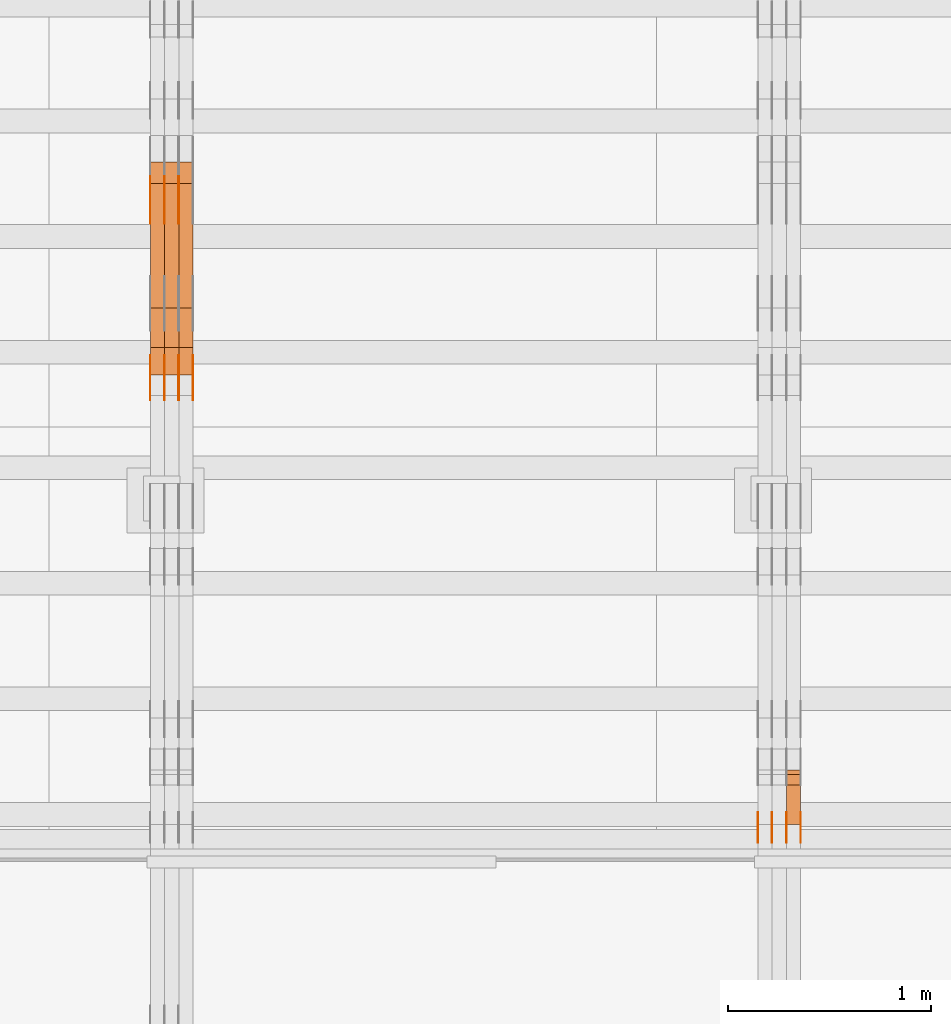
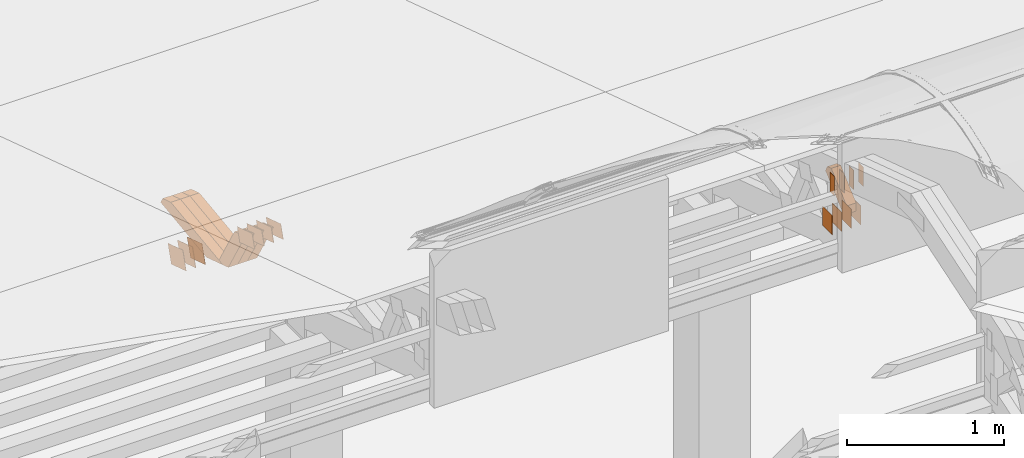
# One storey, part 288 of 385: 30 proxies.
"""IFC2X3 building model written with IfcOpenShell, lengths in millimetres."""

import ifcopenshell
import ifcopenshell.guid

model = None  # the IFC model being written
_history = None  # IfcOwnerHistory: only IFC2X3 demands one
_inside = {}  # id of a spatial element -> (the spatial element, [elements in it])
_under = {}  # id of a project, library or spatial element -> (it, [spatial elements below it])
_declared = {}  # id of a project -> (the project, [libraries it declares])
_typed = {}  # id of a type object -> (the type object, [elements of that type])
_made_of = {}  # id of a material, layer set ... -> (it, [elements and type objects made of it])


def new_model(schema):
    """Start an empty IFC model of exactly this schema.

    Asked for "IFC4X3", IfcOpenShell would pick the latest addendum, in which some entities
    have other attributes; the version numbers below select the first issue.
    IFC2X3 requires an IfcOwnerHistory on every rooted entity: one is made here for all.
    """
    global model, _history
    if schema == "IFC4X3":
        model = ifcopenshell.file(schema_version=(4, 3, 0, 0))
    else:
        model = ifcopenshell.file(schema=schema)
    _inside.clear()
    _under.clear()
    _declared.clear()
    _typed.clear()
    _made_of.clear()
    _history = None
    if model.schema == "IFC2X3":
        org = make("IfcOrganization", Name="unknown")
        user = make(
            "IfcPersonAndOrganization",
            ThePerson=make("IfcPerson", FamilyName="unknown"),
            TheOrganization=org,
        )
        app = make(
            "IfcApplication",
            ApplicationDeveloper=org,
            Version="unknown",
            ApplicationFullName="unknown",
            ApplicationIdentifier="unknown",
        )
        _history = make(
            "IfcOwnerHistory",
            OwningUser=user,
            OwningApplication=app,
            ChangeAction="ADDED",
            CreationDate=0,
        )
    return model


def make(cls, **values):
    """One entity of the class cls with the attributes given. An attribute that is None is left unset."""
    return model.create_entity(
        cls, **{name: value for name, value in values.items() if value is not None}
    )


def entity(cls, *values):
    """Any entity or typed value of the class cls, its attributes in the order of the schema. None: left unset."""
    e = model.create_entity(cls)
    for i, value in enumerate(values):
        if value is not None:
            e[i] = value
    return e


def rooted(cls, **values):
    """An entity with a GlobalId (a new one), such as an element, a storey or a relation."""
    return make(cls, GlobalId=ifcopenshell.guid.new(), OwnerHistory=_history, **values)


def si_unit(unit_type, name, prefix=None):
    """IfcSIUnit, for example si_unit("LENGTHUNIT", "METRE", prefix="MILLI")."""
    return make("IfcSIUnit", UnitType=unit_type, Prefix=prefix, Name=name)


def converted_unit(unit_type, name, factor, base, dimensions=None, offset=None):
    """IfcConversionBasedUnit, such as the inch: factor (a typed value) times the base unit."""
    return make(
        "IfcConversionBasedUnit"
        if offset is None
        else "IfcConversionBasedUnitWithOffset",
        ConversionOffset=offset,
        Dimensions=None
        if dimensions is None
        else entity("IfcDimensionalExponents", *dimensions),
        UnitType=unit_type,
        Name=name,
        ConversionFactor=make(
            "IfcMeasureWithUnit", ValueComponent=factor, UnitComponent=base
        ),
    )


def derived_unit(unit_type, elements):
    """IfcDerivedUnit: a product of units, each with its exponent."""
    return make(
        "IfcDerivedUnit",
        Elements=[
            make("IfcDerivedUnitElement", Unit=unit, Exponent=power)
            for unit, power in elements
        ],
        UnitType=unit_type,
    )


def assignment(units):
    """IfcUnitAssignment: the units of a project."""
    return None if units is None else make("IfcUnitAssignment", Units=units)


def point(xyz):
    """IfcCartesianPoint."""
    return None if xyz is None else make("IfcCartesianPoint", Coordinates=xyz)


def direction(xyz):
    """IfcDirection."""
    return None if xyz is None else make("IfcDirection", DirectionRatios=xyz)


def frame(location, z_axis=None, x_axis=None):
    """IfcAxis2Placement3D, a coordinate frame: its origin and axes. An axis left out is left unset."""
    return make(
        "IfcAxis2Placement3D",
        Location=point(location),
        Axis=direction(z_axis),
        RefDirection=direction(x_axis),
    )


def frame_2d(location, x_axis=None):
    """IfcAxis2Placement2D, a coordinate frame in the plane: its origin and x axis."""
    return make(
        "IfcAxis2Placement2D", Location=point(location), RefDirection=direction(x_axis)
    )


def origin():
    """The frame at (0, 0, 0) with its axes left unset."""
    return frame((0.0, 0.0, 0.0))


def origin_2d_with_axis():
    """The frame at (0, 0) in the plane with the x axis (1, 0) written out."""
    return frame_2d((0.0, 0.0), x_axis=(1.0, 0.0))


def place(relative_to, where):
    """IfcLocalPlacement: puts the frame where relative to a parent placement (None: the world)."""
    return make(
        "IfcLocalPlacement", PlacementRelTo=relative_to, RelativePlacement=where
    )


def context(
    kind, dimensions, precision=None, world=None, true_north=None, identifier=None
):
    """IfcGeometricRepresentationContext, for example the 3D "Model" context."""
    return make(
        "IfcGeometricRepresentationContext",
        ContextIdentifier=identifier,
        ContextType=kind,
        CoordinateSpaceDimension=dimensions,
        Precision=precision,
        WorldCoordinateSystem=world,
        TrueNorth=true_north,
    )


def subcontext(parent, identifier, kind, view, scale=None):
    """IfcGeometricRepresentationSubContext, for example "Body" below "Model"."""
    return make(
        "IfcGeometricRepresentationSubContext",
        ContextIdentifier=identifier,
        ContextType=kind,
        ParentContext=parent,
        TargetScale=scale,
        TargetView=view,
    )


def project(units=None, contexts=None):
    """IfcProject with its units and contexts."""
    return rooted(
        "IfcProject",
        Name="project",
        RepresentationContexts=contexts,
        UnitsInContext=assignment(units),
    )


def spatial(cls, under=None, at=None, **own):
    """A site, building, storey or space (cls), placed at a placement, below another one or the project."""
    s = rooted(cls, ObjectPlacement=at, **own)
    if under is not None:
        _under.setdefault(under.id(), (under, []))[1].append(s)
    return s


def polyline(points):
    """IfcPolyline through the points."""
    return make("IfcPolyline", Points=[point(p) for p in points])


def profile(cls, at=None, kind="AREA", **sizes):
    """A parametric profile (cls). Its sizes go by their IFC names, for example OverallWidth=200.0."""
    return make(cls, ProfileType=kind, Position=at, **sizes)


def rectangle(**sizes):
    """IfcRectangleProfileDef."""
    return profile("IfcRectangleProfileDef", **sizes)


def outline(outer, holes=None, kind="AREA"):
    """IfcArbitraryClosedProfileDef: a profile drawn as a closed curve; with holes, ...WithVoids."""
    if holes is None:
        return make("IfcArbitraryClosedProfileDef", ProfileType=kind, OuterCurve=outer)
    return make(
        "IfcArbitraryProfileDefWithVoids",
        ProfileType=kind,
        OuterCurve=outer,
        InnerCurves=holes,
    )


def extrude(swept, where, along, depth):
    """IfcExtrudedAreaSolid: the profile swept, set in the frame where, extruded along a direction by depth."""
    return make(
        "IfcExtrudedAreaSolid",
        SweptArea=swept,
        Position=where,
        ExtrudedDirection=direction(along),
        Depth=depth,
    )


def shape(context_of_items, identifier, shape_type, items):
    """IfcShapeRepresentation: the items that make up one representation, for example the "Body"."""
    return make(
        "IfcShapeRepresentation",
        ContextOfItems=context_of_items,
        RepresentationIdentifier=identifier,
        RepresentationType=shape_type,
        Items=items,
    )


def source(mapping_origin, context_of_items, identifier, shape_type, items):
    """IfcRepresentationMap: a shape defined once, which mapped items show again and again."""
    return make(
        "IfcRepresentationMap",
        MappingOrigin=mapping_origin,
        MappedRepresentation=shape(context_of_items, identifier, shape_type, items),
    )


def transform(
    local_origin,
    x_axis=None,
    y_axis=None,
    z_axis=None,
    scale=None,
    scale2=None,
    scale3=None,
    uniform=True,
):
    """IfcCartesianTransformationOperator3D, or its non-uniform kind. x_axis, y_axis, z_axis: its Axis1, 2, 3."""
    if uniform:
        return make(
            "IfcCartesianTransformationOperator3D",
            Axis1=direction(x_axis),
            Axis2=direction(y_axis),
            LocalOrigin=point(local_origin),
            Scale=scale,
            Axis3=direction(z_axis),
        )
    return make(
        "IfcCartesianTransformationOperator3DnonUniform",
        Axis1=direction(x_axis),
        Axis2=direction(y_axis),
        LocalOrigin=point(local_origin),
        Scale=scale,
        Axis3=direction(z_axis),
        Scale2=scale2,
        Scale3=scale3,
    )


def mapped(mapping_source, mapping_target):
    """IfcMappedItem: shows the shape of a source again, moved by a transform."""
    return make(
        "IfcMappedItem", MappingSource=mapping_source, MappingTarget=mapping_target
    )


def material(Name=None, Category=None):
    """IfcMaterial."""
    return make("IfcMaterial", Name=Name, Category=Category)


def made_of(thing, what):
    """Note that an element or type object is made of a material, layer set ...; save() writes the relation."""
    if what is not None:
        _made_of.setdefault(what.id(), (what, []))[1].append(thing)
    return thing


def type_object(cls, material=None, **own):
    """A type object (cls), such as IfcWallType, which elements share."""
    return made_of(rooted(cls, **own), material)


def type_shapes(of_type, sources):
    """Give a type object the sources (RepresentationMaps) that its elements show as mapped items."""
    of_type.RepresentationMaps = sources


def element(
    cls,
    number,
    at=None,
    inside=None,
    cuts=None,
    type_object=None,
    material=None,
    context=None,
    identifier="Body",
    shape_type=None,
    held_by="IfcProductDefinitionShape",
    body=None,
    shapes=None,
    **own,
):
    """One element of the class cls, such as IfcWall. Its Tag is "e" and its number.

    at: its placement. inside: the storey or other place that contains it. cuts: it is an
    opening in that element (IfcRelVoidsElement). A single representation is given by context,
    identifier, shape_type and body (its items); several are given by shapes. held_by: the class
    of the entity that holds the representations. save() writes the other relations.
    """
    e = rooted(cls, Tag="e%d" % number, ObjectPlacement=at, **own)
    if body is not None:
        shapes = [shape(context, identifier, shape_type, body)]
    if shapes is not None:
        e.Representation = make(held_by, Representations=shapes)
    if inside is not None:
        _inside.setdefault(inside.id(), (inside, []))[1].append(e)
    if cuts is not None:
        rooted(
            "IfcRelVoidsElement", RelatingBuildingElement=cuts, RelatedOpeningElement=e
        )
    if type_object is not None:
        _typed.setdefault(type_object.id(), (type_object, []))[1].append(e)
    return made_of(e, material)


def aggregate(whole, parts):
    """IfcRelAggregates: a whole, such as a stair, and the parts it consists of."""
    return rooted("IfcRelAggregates", RelatingObject=whole, RelatedObjects=parts)


def save(model, path):
    """Write the relations noted so far, then the file.

    IfcRelAggregates (storeys below a building ...), IfcRelContainedInSpatialStructure (elements
    in a storey), IfcRelDefinesByType, IfcRelAssociatesMaterial and IfcRelDeclares: one each for
    every whole, place, type object, material and project.
    """
    for whole, parts in _under.values():
        aggregate(whole, parts)
    for where, things in _inside.values():
        rooted(
            "IfcRelContainedInSpatialStructure",
            RelatedElements=things,
            RelatingStructure=where,
        )
    for kind, things in _typed.values():
        rooted("IfcRelDefinesByType", RelatedObjects=things, RelatingType=kind)
    for what, things in _made_of.values():
        rooted("IfcRelAssociatesMaterial", RelatedObjects=things, RelatingMaterial=what)
    for by, libraries in _declared.values():
        rooted("IfcRelDeclares", RelatingContext=by, RelatedDefinitions=libraries)
    model.write(path)


model = new_model("IFC2X3")

# Units and contexts
model_context = context("Model", 3, precision=0.01, world=origin(), true_north=direction((6.12303176911189e-17, 1.0)))
body_context = subcontext(model_context, "Body", "Model", "MODEL_VIEW")
ifc_project = project(units=[si_unit("LENGTHUNIT", "METRE", prefix="MILLI"), si_unit("AREAUNIT", "SQUARE_METRE"), si_unit("VOLUMEUNIT", "CUBIC_METRE"), converted_unit("PLANEANGLEUNIT", "DEGREE", entity("IfcRatioMeasure", 0.0174532925199433), si_unit("PLANEANGLEUNIT", "RADIAN"), dimensions=[0, 0, 0, 0, 0, 0, 0]), si_unit("MASSUNIT", "GRAM", prefix="KILO"), derived_unit("MASSDENSITYUNIT", [(si_unit("MASSUNIT", "GRAM", prefix="KILO"), 1), (si_unit("LENGTHUNIT", "METRE"), -3)]), si_unit("TIMEUNIT", "SECOND"), si_unit("FREQUENCYUNIT", "HERTZ"), si_unit("THERMODYNAMICTEMPERATUREUNIT", "DEGREE_CELSIUS"), derived_unit("THERMALTRANSMITTANCEUNIT", [(si_unit("MASSUNIT", "GRAM", prefix="KILO"), 1), (si_unit("THERMODYNAMICTEMPERATUREUNIT", "KELVIN"), -1), (si_unit("TIMEUNIT", "SECOND"), -3)]), derived_unit("VOLUMETRICFLOWRATEUNIT", [(si_unit("LENGTHUNIT", "METRE"), 3), (si_unit("TIMEUNIT", "SECOND"), -1)]), si_unit("ELECTRICCURRENTUNIT", "AMPERE"), si_unit("ELECTRICVOLTAGEUNIT", "VOLT"), si_unit("POWERUNIT", "WATT"), si_unit("FORCEUNIT", "NEWTON", prefix="KILO"), si_unit("ILLUMINANCEUNIT", "LUX"), si_unit("LUMINOUSFLUXUNIT", "LUMEN"), si_unit("LUMINOUSINTENSITYUNIT", "CANDELA"), derived_unit("USERDEFINED", [(si_unit("MASSUNIT", "GRAM", prefix="KILO"), -1), (si_unit("LENGTHUNIT", "METRE"), -2), (si_unit("TIMEUNIT", "SECOND"), 3), (si_unit("LUMINOUSFLUXUNIT", "LUMEN"), 1)]), derived_unit("LINEARVELOCITYUNIT", [(si_unit("LENGTHUNIT", "METRE"), 1), (si_unit("TIMEUNIT", "SECOND"), -1)]), si_unit("PRESSUREUNIT", "PASCAL"), derived_unit("USERDEFINED", [(si_unit("LENGTHUNIT", "METRE"), -2), (si_unit("MASSUNIT", "GRAM", prefix="KILO"), 1), (si_unit("TIMEUNIT", "SECOND"), -2)])], contexts=[model_context])

# Site, building, storey
site_placement = place(None, origin())
site = spatial("IfcSite", under=ifc_project, at=site_placement, CompositionType="ELEMENT")
building_placement = place(site_placement, origin())
building = spatial("IfcBuilding", under=site, at=building_placement, CompositionType="ELEMENT")
storey_placement = place(building_placement, origin())
storey = spatial("IfcBuildingStorey", under=building, at=storey_placement, Name="Default", CompositionType="ELEMENT", Elevation=0.0)

# Proxies
ifc_material_1 = material(Name="IfcSurfaceStyle #446402")
building_element_proxy_type_1 = type_object("IfcBuildingElementProxyType", PredefinedType="NOTDEFINED", material=ifc_material_1)
shared_shape_1 = source(origin(), body_context, "Body", "SweptSolid", [
    extrude(rectangle(XDim=150.0, YDim=120.0, at=origin_2d_with_axis()), frame((75.0, 60.0, 0.0), z_axis=(0.0, 0.0, 1.0), x_axis=(-1.0, 0.0, 0.0)), (0.0, 0.0, 1.0), 1.3),
])
type_shapes(building_element_proxy_type_1, [shared_shape_1])
proxy_1_placement = place(building_placement, frame((36386.3, 15840.0, 3652.70166015625), z_axis=(-1.0, 0.0, 0.0), x_axis=(0.0, 0.0, -1.0)))
element("IfcBuildingElementProxy", 1, at=proxy_1_placement, inside=storey, type_object=building_element_proxy_type_1, material=ifc_material_1, context=body_context, shape_type="MappedRepresentation", body=[
    mapped(shared_shape_1, transform((0.0, 0.0, 0.0), scale=1.0)),
])
ifc_material_2 = material(Name="IfcSurfaceStyle #446345")
building_element_proxy_type_2 = type_object("IfcBuildingElementProxyType", PredefinedType="NOTDEFINED", material=ifc_material_2)
shared_shape_2 = source(origin(), body_context, "Body", "SweptSolid", [
    extrude(rectangle(XDim=150.0, YDim=120.0, at=origin_2d_with_axis()), frame((75.0, 60.0, 0.0), z_axis=(0.0, 0.0, 1.0), x_axis=(-1.0, 0.0, 0.0)), (0.0, 0.0, 1.0), 1.3),
])
type_shapes(building_element_proxy_type_2, [shared_shape_2])
proxy_2_placement = place(building_placement, frame((36315.0, 15840.0, 3652.70166015625), z_axis=(-1.0, 0.0, 0.0), x_axis=(0.0, 0.0, -1.0)))
element("IfcBuildingElementProxy", 2, at=proxy_2_placement, inside=storey, type_object=building_element_proxy_type_2, material=ifc_material_2, context=body_context, shape_type="MappedRepresentation", body=[
    mapped(shared_shape_2, transform((0.0, 0.0, 0.0), scale=1.0)),
])
ifc_material_3 = material(Name="IfcSurfaceStyle #446288")
building_element_proxy_type_3 = type_object("IfcBuildingElementProxyType", PredefinedType="NOTDEFINED", material=ifc_material_3)
shared_shape_3 = source(origin(), body_context, "Body", "SweptSolid", [
    extrude(rectangle(XDim=150.0, YDim=120.0, at=origin_2d_with_axis()), frame((75.0, 60.0, 0.0), z_axis=(0.0, 0.0, 1.0), x_axis=(-1.0, 0.0, 0.0)), (0.0, 0.0, 1.0), 1.3),
])
type_shapes(building_element_proxy_type_3, [shared_shape_3])
proxy_3_placement = place(building_placement, frame((36316.3, 15840.0, 3652.70166015625), z_axis=(-1.0, 0.0, 0.0), x_axis=(0.0, 0.0, -1.0)))
element("IfcBuildingElementProxy", 3, at=proxy_3_placement, inside=storey, type_object=building_element_proxy_type_3, material=ifc_material_3, context=body_context, shape_type="MappedRepresentation", body=[
    mapped(shared_shape_3, transform((0.0, 0.0, 0.0), scale=1.0)),
])
ifc_material_4 = material(Name="IfcSurfaceStyle #446231")
building_element_proxy_type_4 = type_object("IfcBuildingElementProxyType", PredefinedType="NOTDEFINED", material=ifc_material_4)
shared_shape_4 = source(origin(), body_context, "Body", "SweptSolid", [
    extrude(rectangle(XDim=150.0, YDim=120.0, at=origin_2d_with_axis()), frame((75.0, 60.0, 0.0), z_axis=(0.0, 0.0, 1.0), x_axis=(-1.0, 0.0, 0.0)), (0.0, 0.0, 1.0), 1.29999999999999),
])
type_shapes(building_element_proxy_type_4, [shared_shape_4])
proxy_4_placement = place(building_placement, frame((36245.0, 15840.0, 3652.70166015625), z_axis=(-1.0, 0.0, 0.0), x_axis=(0.0, 0.0, -1.0)))
element("IfcBuildingElementProxy", 4, at=proxy_4_placement, inside=storey, type_object=building_element_proxy_type_4, material=ifc_material_4, context=body_context, shape_type="MappedRepresentation", body=[
    mapped(shared_shape_4, transform((0.0, 0.0, 0.0), scale=1.0)),
])
ifc_material_5 = material(Name="IfcSurfaceStyle #446174")
building_element_proxy_type_5 = type_object("IfcBuildingElementProxyType", PredefinedType="NOTDEFINED", material=ifc_material_5)
shared_shape_5 = source(origin(), body_context, "Body", "SweptSolid", [
    extrude(rectangle(XDim=150.0, YDim=120.0, at=origin_2d_with_axis()), frame((75.0, 60.0, 0.0), z_axis=(0.0, 0.0, 1.0), x_axis=(-1.0, 0.0, 0.0)), (0.0, 0.0, 1.0), 1.29999999999999),
])
type_shapes(building_element_proxy_type_5, [shared_shape_5])
proxy_5_placement = place(building_placement, frame((36246.3, 15840.0, 3652.70166015625), z_axis=(-1.0, 0.0, 0.0), x_axis=(0.0, 0.0, -1.0)))
element("IfcBuildingElementProxy", 5, at=proxy_5_placement, inside=storey, type_object=building_element_proxy_type_5, material=ifc_material_5, context=body_context, shape_type="MappedRepresentation", body=[
    mapped(shared_shape_5, transform((0.0, 0.0, 0.0), scale=1.0)),
])
ifc_material_6 = material(Name="IfcSurfaceStyle #446117")
building_element_proxy_type_6 = type_object("IfcBuildingElementProxyType", PredefinedType="NOTDEFINED", material=ifc_material_6)
shared_shape_6 = source(origin(), body_context, "Body", "SweptSolid", [
    extrude(rectangle(XDim=150.0, YDim=120.0, at=origin_2d_with_axis()), frame((75.0, 60.0, 0.0), z_axis=(0.0, 0.0, 1.0), x_axis=(-1.0, 0.0, 0.0)), (0.0, 0.0, 1.0), 1.29999999999999),
])
type_shapes(building_element_proxy_type_6, [shared_shape_6])
proxy_6_placement = place(building_placement, frame((36175.0, 15840.0, 3652.70166015625), z_axis=(-1.0, 0.0, 0.0), x_axis=(0.0, 0.0, -1.0)))
element("IfcBuildingElementProxy", 6, at=proxy_6_placement, inside=storey, type_object=building_element_proxy_type_6, material=ifc_material_6, context=body_context, shape_type="MappedRepresentation", body=[
    mapped(shared_shape_6, transform((0.0, 0.0, 0.0), scale=1.0)),
])
ifc_material_7 = material(Name="IfcSurfaceStyle #440930")
building_element_proxy_type_7 = type_object("IfcBuildingElementProxyType", PredefinedType="NOTDEFINED", material=ifc_material_7)
shared_shape_7 = source(origin(), body_context, "Body", "SweptSolid", [
    extrude(rectangle(XDim=150.0, YDim=60.0, at=origin_2d_with_axis()), frame((75.0000705696311, 30.0, 0.0), z_axis=(0.0, 0.0, 1.0), x_axis=(-1.0, 0.0, 0.0)), (0.0, 0.0, 1.0), 1.3),
])
type_shapes(building_element_proxy_type_7, [shared_shape_7])
proxy_7_placement = place(building_placement, frame((36386.3, 15750.0, 3972.59919166338), z_axis=(-1.0, 0.0, 0.0), x_axis=(0.0, 0.0, -1.0)))
element("IfcBuildingElementProxy", 7, at=proxy_7_placement, inside=storey, type_object=building_element_proxy_type_7, material=ifc_material_7, context=body_context, shape_type="MappedRepresentation", body=[
    mapped(shared_shape_7, transform((0.0, 0.0, 0.0), scale=1.0)),
])
ifc_material_8 = material(Name="IfcSurfaceStyle #440873")
building_element_proxy_type_8 = type_object("IfcBuildingElementProxyType", PredefinedType="NOTDEFINED", material=ifc_material_8)
shared_shape_8 = source(origin(), body_context, "Body", "SweptSolid", [
    extrude(rectangle(XDim=150.0, YDim=60.0, at=origin_2d_with_axis()), frame((75.0000705696311, 30.0, 0.0), z_axis=(0.0, 0.0, 1.0), x_axis=(-1.0, 0.0, 0.0)), (0.0, 0.0, 1.0), 1.3),
])
type_shapes(building_element_proxy_type_8, [shared_shape_8])
proxy_8_placement = place(building_placement, frame((36315.0, 15750.0, 3972.59919166338), z_axis=(-1.0, 0.0, 0.0), x_axis=(0.0, 0.0, -1.0)))
element("IfcBuildingElementProxy", 8, at=proxy_8_placement, inside=storey, type_object=building_element_proxy_type_8, material=ifc_material_8, context=body_context, shape_type="MappedRepresentation", body=[
    mapped(shared_shape_8, transform((0.0, 0.0, 0.0), scale=1.0)),
])
ifc_material_9 = material(Name="IfcSurfaceStyle #440816")
building_element_proxy_type_9 = type_object("IfcBuildingElementProxyType", PredefinedType="NOTDEFINED", material=ifc_material_9)
shared_shape_9 = source(origin(), body_context, "Body", "SweptSolid", [
    extrude(rectangle(XDim=150.0, YDim=60.0, at=origin_2d_with_axis()), frame((75.0000705696311, 30.0, 0.0), z_axis=(0.0, 0.0, 1.0), x_axis=(-1.0, 0.0, 0.0)), (0.0, 0.0, 1.0), 1.3),
])
type_shapes(building_element_proxy_type_9, [shared_shape_9])
proxy_9_placement = place(building_placement, frame((36316.3, 15750.0, 3972.59919166338), z_axis=(-1.0, 0.0, 0.0), x_axis=(0.0, 0.0, -1.0)))
element("IfcBuildingElementProxy", 9, at=proxy_9_placement, inside=storey, type_object=building_element_proxy_type_9, material=ifc_material_9, context=body_context, shape_type="MappedRepresentation", body=[
    mapped(shared_shape_9, transform((0.0, 0.0, 0.0), scale=1.0)),
])
ifc_material_10 = material(Name="IfcSurfaceStyle #440759")
building_element_proxy_type_10 = type_object("IfcBuildingElementProxyType", PredefinedType="NOTDEFINED", material=ifc_material_10)
shared_shape_10 = source(origin(), body_context, "Body", "SweptSolid", [
    extrude(rectangle(XDim=150.0, YDim=60.0, at=origin_2d_with_axis()), frame((75.0000705696311, 30.0, 0.0), z_axis=(0.0, 0.0, 1.0), x_axis=(-1.0, 0.0, 0.0)), (0.0, 0.0, 1.0), 1.29999999999999),
])
type_shapes(building_element_proxy_type_10, [shared_shape_10])
proxy_10_placement = place(building_placement, frame((36245.0, 15750.0, 3972.59919166338), z_axis=(-1.0, 0.0, 0.0), x_axis=(0.0, 0.0, -1.0)))
element("IfcBuildingElementProxy", 10, at=proxy_10_placement, inside=storey, type_object=building_element_proxy_type_10, material=ifc_material_10, context=body_context, shape_type="MappedRepresentation", body=[
    mapped(shared_shape_10, transform((0.0, 0.0, 0.0), scale=1.0)),
])
ifc_material_11 = material(Name="IfcSurfaceStyle #440702")
building_element_proxy_type_11 = type_object("IfcBuildingElementProxyType", PredefinedType="NOTDEFINED", material=ifc_material_11)
shared_shape_11 = source(origin(), body_context, "Body", "SweptSolid", [
    extrude(rectangle(XDim=150.0, YDim=60.0, at=origin_2d_with_axis()), frame((75.0000705696311, 30.0, 0.0), z_axis=(0.0, 0.0, 1.0), x_axis=(-1.0, 0.0, 0.0)), (0.0, 0.0, 1.0), 1.29999999999999),
])
type_shapes(building_element_proxy_type_11, [shared_shape_11])
proxy_11_placement = place(building_placement, frame((36246.3, 15750.0, 3972.59919166338), z_axis=(-1.0, 0.0, 0.0), x_axis=(0.0, 0.0, -1.0)))
element("IfcBuildingElementProxy", 11, at=proxy_11_placement, inside=storey, type_object=building_element_proxy_type_11, material=ifc_material_11, context=body_context, shape_type="MappedRepresentation", body=[
    mapped(shared_shape_11, transform((0.0, 0.0, 0.0), scale=1.0)),
])
ifc_material_12 = material(Name="IfcSurfaceStyle #440645")
building_element_proxy_type_12 = type_object("IfcBuildingElementProxyType", PredefinedType="NOTDEFINED", material=ifc_material_12)
shared_shape_12 = source(origin(), body_context, "Body", "SweptSolid", [
    extrude(rectangle(XDim=150.0, YDim=60.0, at=origin_2d_with_axis()), frame((75.0000705696311, 30.0, 0.0), z_axis=(0.0, 0.0, 1.0), x_axis=(-1.0, 0.0, 0.0)), (0.0, 0.0, 1.0), 1.29999999999999),
])
type_shapes(building_element_proxy_type_12, [shared_shape_12])
proxy_12_placement = place(building_placement, frame((36175.0, 15750.0, 3972.59919166338), z_axis=(-1.0, 0.0, 0.0), x_axis=(0.0, 0.0, -1.0)))
element("IfcBuildingElementProxy", 12, at=proxy_12_placement, inside=storey, type_object=building_element_proxy_type_12, material=ifc_material_12, context=body_context, shape_type="MappedRepresentation", body=[
    mapped(shared_shape_12, transform((0.0, 0.0, 0.0), scale=1.0)),
])
ifc_material_13 = material(Name="IfcSurfaceStyle #431561")
building_element_proxy_type_13 = type_object("IfcBuildingElementProxyType", Name="T1-W50 431559", PredefinedType="NOTDEFINED", material=ifc_material_13)
shared_shape_13 = source(origin(), body_context, "Body", "SweptSolid", [
    extrude(outline(polyline([(-128.56619634284, -47.4999385885712), (133.151257249084, -47.4999385885712), (161.172800006526, -0.000129729183733609), (147.291467726413, 47.500068317755), (-142.513973767368, 47.500068317755), (-170.535354871815, -0.000129729183754689), (-128.56619634284, -47.4999385885712)])), frame((161.17310141218, 47.5001898716564, 0.0), z_axis=(0.0, 0.0, 1.0), x_axis=(-1.0, 0.0, 0.0)), (0.0, 0.0, 1.0), 70.0),
])
type_shapes(building_element_proxy_type_13, [shared_shape_13])
proxy_13_placement = place(building_placement, frame((36385.0, 16060.0297689714, 3761.73994820667), z_axis=(-1.0, 0.0, 0.0), x_axis=(0.0, -0.749388407538668, -0.662130662820156)))
element("IfcBuildingElementProxy", 13, at=proxy_13_placement, inside=storey, type_object=building_element_proxy_type_13, material=ifc_material_13, Name="T1-W50", context=body_context, shape_type="MappedRepresentation", body=[
    mapped(shared_shape_13, transform((0.0, 0.0, 0.0), scale=1.0)),
])
ifc_material_14 = material(Name="IfcSurfaceStyle #409519")
building_element_proxy_type_14 = type_object("IfcBuildingElementProxyType", PredefinedType="NOTDEFINED", material=ifc_material_14)
shared_shape_14 = source(origin(), body_context, "Body", "SweptSolid", [
    extrude(outline(polyline([(-99.999796294464, -72.0000050220467), (99.9998768370438, -72.0000050220467), (100.000260677528, 72.0000050220467), (-100.000341220108, 72.0000050220467), (-99.999796294464, -72.0000050220467)])), frame((100.000260677528, 72.0000050220467, 0.0), z_axis=(0.0, 0.0, 1.0), x_axis=(-1.0, 0.0, 0.0)), (0.0, 0.0, 1.0), 1.3),
])
type_shapes(building_element_proxy_type_14, [shared_shape_14])
proxy_14_placement = place(building_placement, frame((33315.0, 18936.3876569477, 2373.90613192527), z_axis=(-1.0, 0.0, 0.0), x_axis=(0.0, -0.951056516295124, 0.309016994375039)))
element("IfcBuildingElementProxy", 14, at=proxy_14_placement, inside=storey, type_object=building_element_proxy_type_14, material=ifc_material_14, context=body_context, shape_type="MappedRepresentation", body=[
    mapped(shared_shape_14, transform((0.0, 0.0, 0.0), scale=1.0)),
])
ifc_material_15 = material(Name="IfcSurfaceStyle #409462")
building_element_proxy_type_15 = type_object("IfcBuildingElementProxyType", PredefinedType="NOTDEFINED", material=ifc_material_15)
shared_shape_15 = source(origin(), body_context, "Body", "SweptSolid", [
    extrude(outline(polyline([(-99.999796294464, -72.0000050220467), (99.9998768370438, -72.0000050220467), (100.000260677528, 72.0000050220467), (-100.000341220108, 72.0000050220467), (-99.999796294464, -72.0000050220467)])), frame((100.000260677528, 72.0000050220467, 0.0), z_axis=(0.0, 0.0, 1.0), x_axis=(-1.0, 0.0, 0.0)), (0.0, 0.0, 1.0), 1.3),
])
type_shapes(building_element_proxy_type_15, [shared_shape_15])
proxy_15_placement = place(building_placement, frame((33316.3, 18936.3876569477, 2373.90613192527), z_axis=(-1.0, 0.0, 0.0), x_axis=(0.0, -0.951056516295124, 0.309016994375039)))
element("IfcBuildingElementProxy", 15, at=proxy_15_placement, inside=storey, type_object=building_element_proxy_type_15, material=ifc_material_15, context=body_context, shape_type="MappedRepresentation", body=[
    mapped(shared_shape_15, transform((0.0, 0.0, 0.0), scale=1.0)),
])
ifc_material_16 = material(Name="IfcSurfaceStyle #409405")
building_element_proxy_type_16 = type_object("IfcBuildingElementProxyType", PredefinedType="NOTDEFINED", material=ifc_material_16)
shared_shape_16 = source(origin(), body_context, "Body", "SweptSolid", [
    extrude(outline(polyline([(-99.999796294464, -72.0000050220467), (99.9998768370438, -72.0000050220467), (100.000260677528, 72.0000050220467), (-100.000341220108, 72.0000050220467), (-99.999796294464, -72.0000050220467)])), frame((100.000260677528, 72.0000050220467, 0.0), z_axis=(0.0, 0.0, 1.0), x_axis=(-1.0, 0.0, 0.0)), (0.0, 0.0, 1.0), 1.29999999999998),
])
type_shapes(building_element_proxy_type_16, [shared_shape_16])
proxy_16_placement = place(building_placement, frame((33245.0, 18936.3876569477, 2373.90613192527), z_axis=(-1.0, 0.0, 0.0), x_axis=(0.0, -0.951056516295124, 0.309016994375039)))
element("IfcBuildingElementProxy", 16, at=proxy_16_placement, inside=storey, type_object=building_element_proxy_type_16, material=ifc_material_16, context=body_context, shape_type="MappedRepresentation", body=[
    mapped(shared_shape_16, transform((0.0, 0.0, 0.0), scale=1.0)),
])
ifc_material_17 = material(Name="IfcSurfaceStyle #409348")
building_element_proxy_type_17 = type_object("IfcBuildingElementProxyType", PredefinedType="NOTDEFINED", material=ifc_material_17)
shared_shape_17 = source(origin(), body_context, "Body", "SweptSolid", [
    extrude(outline(polyline([(-99.999796294464, -72.0000050220467), (99.9998768370438, -72.0000050220467), (100.000260677528, 72.0000050220467), (-100.000341220108, 72.0000050220467), (-99.999796294464, -72.0000050220467)])), frame((100.000260677528, 72.0000050220467, 0.0), z_axis=(0.0, 0.0, 1.0), x_axis=(-1.0, 0.0, 0.0)), (0.0, 0.0, 1.0), 1.29999999999998),
])
type_shapes(building_element_proxy_type_17, [shared_shape_17])
proxy_17_placement = place(building_placement, frame((33246.3, 18936.3876569477, 2373.90613192527), z_axis=(-1.0, 0.0, 0.0), x_axis=(0.0, -0.951056516295124, 0.309016994375039)))
element("IfcBuildingElementProxy", 17, at=proxy_17_placement, inside=storey, type_object=building_element_proxy_type_17, material=ifc_material_17, context=body_context, shape_type="MappedRepresentation", body=[
    mapped(shared_shape_17, transform((0.0, 0.0, 0.0), scale=1.0)),
])
ifc_material_18 = material(Name="IfcSurfaceStyle #409291")
building_element_proxy_type_18 = type_object("IfcBuildingElementProxyType", PredefinedType="NOTDEFINED", material=ifc_material_18)
shared_shape_18 = source(origin(), body_context, "Body", "SweptSolid", [
    extrude(outline(polyline([(-99.999796294464, -72.0000050220467), (99.9998768370438, -72.0000050220467), (100.000260677528, 72.0000050220467), (-100.000341220108, 72.0000050220467), (-99.999796294464, -72.0000050220467)])), frame((100.000260677528, 72.0000050220467, 0.0), z_axis=(0.0, 0.0, 1.0), x_axis=(-1.0, 0.0, 0.0)), (0.0, 0.0, 1.0), 1.29999999999999),
])
type_shapes(building_element_proxy_type_18, [shared_shape_18])
proxy_18_placement = place(building_placement, frame((33175.0, 18936.3876569477, 2373.90613192527), z_axis=(-1.0, 0.0, 0.0), x_axis=(0.0, -0.951056516295124, 0.309016994375039)))
element("IfcBuildingElementProxy", 18, at=proxy_18_placement, inside=storey, type_object=building_element_proxy_type_18, material=ifc_material_18, context=body_context, shape_type="MappedRepresentation", body=[
    mapped(shared_shape_18, transform((0.0, 0.0, 0.0), scale=1.0)),
])
ifc_material_19 = material(Name="IfcSurfaceStyle #405130")
building_element_proxy_type_19 = type_object("IfcBuildingElementProxyType", PredefinedType="NOTDEFINED", material=ifc_material_19)
shared_shape_19 = source(origin(), body_context, "Body", "SweptSolid", [
    extrude(outline(polyline([(-99.9999427841299, -54.0000599375792), (99.9996549037756, -54.0000599375792), (100.000407167194, 54.0000599375792), (-100.00011928684, 54.0000599375792), (-99.9999427841299, -54.0000599375792)])), frame((100.000407167194, 54.0000599375792, 0.0), z_axis=(0.0, 0.0, 1.0), x_axis=(-1.0, 0.0, 0.0)), (0.0, 0.0, 1.0), 1.3),
])
type_shapes(building_element_proxy_type_19, [shared_shape_19])
proxy_19_placement = place(building_placement, frame((33386.3, 18065.0682492591, 3072.55239547302), z_axis=(-1.0, 0.0, 0.0), x_axis=(0.0, -0.951056516295154, 0.309016994374948)))
element("IfcBuildingElementProxy", 19, at=proxy_19_placement, inside=storey, type_object=building_element_proxy_type_19, material=ifc_material_19, context=body_context, shape_type="MappedRepresentation", body=[
    mapped(shared_shape_19, transform((0.0, 0.0, 0.0), scale=1.0)),
])
ifc_material_20 = material(Name="IfcSurfaceStyle #405073")
building_element_proxy_type_20 = type_object("IfcBuildingElementProxyType", PredefinedType="NOTDEFINED", material=ifc_material_20)
shared_shape_20 = source(origin(), body_context, "Body", "SweptSolid", [
    extrude(outline(polyline([(-99.9999427841299, -54.0000599375792), (99.9996549037756, -54.0000599375792), (100.000407167194, 54.0000599375792), (-100.00011928684, 54.0000599375792), (-99.9999427841299, -54.0000599375792)])), frame((100.000407167194, 54.0000599375792, 0.0), z_axis=(0.0, 0.0, 1.0), x_axis=(-1.0, 0.0, 0.0)), (0.0, 0.0, 1.0), 1.3),
])
type_shapes(building_element_proxy_type_20, [shared_shape_20])
proxy_20_placement = place(building_placement, frame((33315.0, 18065.0682492591, 3072.55239547302), z_axis=(-1.0, 0.0, 0.0), x_axis=(0.0, -0.951056516295154, 0.309016994374948)))
element("IfcBuildingElementProxy", 20, at=proxy_20_placement, inside=storey, type_object=building_element_proxy_type_20, material=ifc_material_20, context=body_context, shape_type="MappedRepresentation", body=[
    mapped(shared_shape_20, transform((0.0, 0.0, 0.0), scale=1.0)),
])
ifc_material_21 = material(Name="IfcSurfaceStyle #405016")
building_element_proxy_type_21 = type_object("IfcBuildingElementProxyType", PredefinedType="NOTDEFINED", material=ifc_material_21)
shared_shape_21 = source(origin(), body_context, "Body", "SweptSolid", [
    extrude(outline(polyline([(-99.9999427841299, -54.0000599375792), (99.9996549037756, -54.0000599375792), (100.000407167194, 54.0000599375792), (-100.00011928684, 54.0000599375792), (-99.9999427841299, -54.0000599375792)])), frame((100.000407167194, 54.0000599375792, 0.0), z_axis=(0.0, 0.0, 1.0), x_axis=(-1.0, 0.0, 0.0)), (0.0, 0.0, 1.0), 1.3),
])
type_shapes(building_element_proxy_type_21, [shared_shape_21])
proxy_21_placement = place(building_placement, frame((33316.3, 18065.0682492591, 3072.55239547302), z_axis=(-1.0, 0.0, 0.0), x_axis=(0.0, -0.951056516295154, 0.309016994374948)))
element("IfcBuildingElementProxy", 21, at=proxy_21_placement, inside=storey, type_object=building_element_proxy_type_21, material=ifc_material_21, context=body_context, shape_type="MappedRepresentation", body=[
    mapped(shared_shape_21, transform((0.0, 0.0, 0.0), scale=1.0)),
])
ifc_material_22 = material(Name="IfcSurfaceStyle #404959")
building_element_proxy_type_22 = type_object("IfcBuildingElementProxyType", PredefinedType="NOTDEFINED", material=ifc_material_22)
shared_shape_22 = source(origin(), body_context, "Body", "SweptSolid", [
    extrude(outline(polyline([(-99.9999427841299, -54.0000599375792), (99.9996549037756, -54.0000599375792), (100.000407167194, 54.0000599375792), (-100.00011928684, 54.0000599375792), (-99.9999427841299, -54.0000599375792)])), frame((100.000407167194, 54.0000599375792, 0.0), z_axis=(0.0, 0.0, 1.0), x_axis=(-1.0, 0.0, 0.0)), (0.0, 0.0, 1.0), 1.29999999999998),
])
type_shapes(building_element_proxy_type_22, [shared_shape_22])
proxy_22_placement = place(building_placement, frame((33245.0, 18065.0682492591, 3072.55239547302), z_axis=(-1.0, 0.0, 0.0), x_axis=(0.0, -0.951056516295154, 0.309016994374948)))
element("IfcBuildingElementProxy", 22, at=proxy_22_placement, inside=storey, type_object=building_element_proxy_type_22, material=ifc_material_22, context=body_context, shape_type="MappedRepresentation", body=[
    mapped(shared_shape_22, transform((0.0, 0.0, 0.0), scale=1.0)),
])
ifc_material_23 = material(Name="IfcSurfaceStyle #404902")
building_element_proxy_type_23 = type_object("IfcBuildingElementProxyType", PredefinedType="NOTDEFINED", material=ifc_material_23)
shared_shape_23 = source(origin(), body_context, "Body", "SweptSolid", [
    extrude(outline(polyline([(-99.9999427841299, -54.0000599375792), (99.9996549037756, -54.0000599375792), (100.000407167194, 54.0000599375792), (-100.00011928684, 54.0000599375792), (-99.9999427841299, -54.0000599375792)])), frame((100.000407167194, 54.0000599375792, 0.0), z_axis=(0.0, 0.0, 1.0), x_axis=(-1.0, 0.0, 0.0)), (0.0, 0.0, 1.0), 1.29999999999998),
])
type_shapes(building_element_proxy_type_23, [shared_shape_23])
proxy_23_placement = place(building_placement, frame((33246.3, 18065.0682492591, 3072.55239547302), z_axis=(-1.0, 0.0, 0.0), x_axis=(0.0, -0.951056516295154, 0.309016994374948)))
element("IfcBuildingElementProxy", 23, at=proxy_23_placement, inside=storey, type_object=building_element_proxy_type_23, material=ifc_material_23, context=body_context, shape_type="MappedRepresentation", body=[
    mapped(shared_shape_23, transform((0.0, 0.0, 0.0), scale=1.0)),
])
ifc_material_24 = material(Name="IfcSurfaceStyle #404845")
building_element_proxy_type_24 = type_object("IfcBuildingElementProxyType", PredefinedType="NOTDEFINED", material=ifc_material_24)
shared_shape_24 = source(origin(), body_context, "Body", "SweptSolid", [
    extrude(outline(polyline([(-99.9999427841299, -54.0000599375792), (99.9996549037756, -54.0000599375792), (100.000407167194, 54.0000599375792), (-100.00011928684, 54.0000599375792), (-99.9999427841299, -54.0000599375792)])), frame((100.000407167194, 54.0000599375792, 0.0), z_axis=(0.0, 0.0, 1.0), x_axis=(-1.0, 0.0, 0.0)), (0.0, 0.0, 1.0), 1.29999999999999),
])
type_shapes(building_element_proxy_type_24, [shared_shape_24])
proxy_24_placement = place(building_placement, frame((33175.0, 18065.0682492591, 3072.55239547302), z_axis=(-1.0, 0.0, 0.0), x_axis=(0.0, -0.951056516295154, 0.309016994374948)))
element("IfcBuildingElementProxy", 24, at=proxy_24_placement, inside=storey, type_object=building_element_proxy_type_24, material=ifc_material_24, context=body_context, shape_type="MappedRepresentation", body=[
    mapped(shared_shape_24, transform((0.0, 0.0, 0.0), scale=1.0)),
])
ifc_material_25 = material(Name="IfcSurfaceStyle #394978")
building_element_proxy_type_25 = type_object("IfcBuildingElementProxyType", Name="T1-W35 394976", PredefinedType="NOTDEFINED", material=ifc_material_25)
shared_shape_25 = source(origin(), body_context, "Body", "SweptSolid", [
    extrude(outline(polyline([(-196.877231354918, -47.499850828051), (197.289756738813, -47.499850828051), (177.380838136073, -0.000131002767018074), (124.615181369032, 47.4999163294346), (-302.408544889, 47.4999163294346), (-196.877231354918, -47.499850828051)])), frame((197.289756738813, 47.5002438363521, 0.0), z_axis=(0.0, 0.0, 1.0), x_axis=(-1.0, 0.0, 0.0)), (0.0, 0.0, 1.0), 70.0),
])
type_shapes(building_element_proxy_type_25, [shared_shape_25])
proxy_25_placement = place(building_placement, frame((33385.0, 18249.5528960018, 2724.16980022534), z_axis=(-1.0, 0.0, 0.0), x_axis=(0.0, -0.5, 0.866025403784439)))
element("IfcBuildingElementProxy", 25, at=proxy_25_placement, inside=storey, type_object=building_element_proxy_type_25, material=ifc_material_25, Name="T1-W35", context=body_context, shape_type="MappedRepresentation", body=[
    mapped(shared_shape_25, transform((0.0, 0.0, 0.0), scale=1.0)),
])
ifc_material_26 = material(Name="IfcSurfaceStyle #394912")
building_element_proxy_type_26 = type_object("IfcBuildingElementProxyType", Name="T1-W35 394910", PredefinedType="NOTDEFINED", material=ifc_material_26)
shared_shape_26 = source(origin(), body_context, "Body", "SweptSolid", [
    extrude(outline(polyline([(-196.877231354918, -47.499850828051), (197.289756738813, -47.499850828051), (177.380838136073, -0.000131002767018074), (124.615181369032, 47.4999163294346), (-302.408544889, 47.4999163294346), (-196.877231354918, -47.499850828051)])), frame((197.289756738813, 47.5002438363521, 0.0), z_axis=(0.0, 0.0, 1.0), x_axis=(-1.0, 0.0, 0.0)), (0.0, 0.0, 1.0), 70.0),
])
type_shapes(building_element_proxy_type_26, [shared_shape_26])
proxy_26_placement = place(building_placement, frame((33315.0, 18249.5528960018, 2724.16980022534), z_axis=(-1.0, 0.0, 0.0), x_axis=(0.0, -0.5, 0.866025403784439)))
element("IfcBuildingElementProxy", 26, at=proxy_26_placement, inside=storey, type_object=building_element_proxy_type_26, material=ifc_material_26, Name="T1-W35", context=body_context, shape_type="MappedRepresentation", body=[
    mapped(shared_shape_26, transform((0.0, 0.0, 0.0), scale=1.0)),
])
ifc_material_27 = material(Name="IfcSurfaceStyle #394846")
building_element_proxy_type_27 = type_object("IfcBuildingElementProxyType", Name="T1-W35 394844", PredefinedType="NOTDEFINED", material=ifc_material_27)
shared_shape_27 = source(origin(), body_context, "Body", "SweptSolid", [
    extrude(outline(polyline([(-196.877231354918, -47.499850828051), (197.289756738813, -47.499850828051), (177.380838136073, -0.000131002767018074), (124.615181369032, 47.4999163294346), (-302.408544889, 47.4999163294346), (-196.877231354918, -47.499850828051)])), frame((197.289756738813, 47.5002438363521, 0.0), z_axis=(0.0, 0.0, 1.0), x_axis=(-1.0, 0.0, 0.0)), (0.0, 0.0, 1.0), 70.0),
])
type_shapes(building_element_proxy_type_27, [shared_shape_27])
proxy_27_placement = place(building_placement, frame((33245.0, 18249.5528960018, 2724.16980022534), z_axis=(-1.0, 0.0, 0.0), x_axis=(0.0, -0.5, 0.866025403784439)))
element("IfcBuildingElementProxy", 27, at=proxy_27_placement, inside=storey, type_object=building_element_proxy_type_27, material=ifc_material_27, Name="T1-W35", context=body_context, shape_type="MappedRepresentation", body=[
    mapped(shared_shape_27, transform((0.0, 0.0, 0.0), scale=1.0)),
])
ifc_material_28 = material(Name="IfcSurfaceStyle #394582")
building_element_proxy_type_28 = type_object("IfcBuildingElementProxyType", Name="T1-W6 394580", PredefinedType="NOTDEFINED", material=ifc_material_28)
shared_shape_28 = source(origin(), body_context, "Body", "SweptSolid", [
    extrude(outline(polyline([(-485.945461934772, -47.500204767976), (183.41906495488, -47.500204767976), (284.061400026172, 0.000179660053988773), (303.127757064591, 47.500114937949), (-284.66276011087, 47.500114937949), (-485.945461934772, -47.500204767976)])), frame((303.127970456024, 47.5001450766485, 0.0), z_axis=(0.0, 0.0, 1.0), x_axis=(-1.0, 0.0, 0.0)), (0.0, 0.0, 1.0), 70.0),
])
type_shapes(building_element_proxy_type_28, [shared_shape_28])
proxy_28_placement = place(building_placement, frame((33385.0, 19075.4826373647, 2770.72729201433), z_axis=(-1.0, 0.0, 0.0), x_axis=(0.0, -0.991969529622927, -0.126477082112413)))
element("IfcBuildingElementProxy", 28, at=proxy_28_placement, inside=storey, type_object=building_element_proxy_type_28, material=ifc_material_28, Name="T1-W6", context=body_context, shape_type="MappedRepresentation", body=[
    mapped(shared_shape_28, transform((0.0, 0.0, 0.0), scale=1.0)),
])
ifc_material_29 = material(Name="IfcSurfaceStyle #394516")
building_element_proxy_type_29 = type_object("IfcBuildingElementProxyType", Name="T1-W6 394514", PredefinedType="NOTDEFINED", material=ifc_material_29)
shared_shape_29 = source(origin(), body_context, "Body", "SweptSolid", [
    extrude(outline(polyline([(-485.945461934772, -47.500204767976), (183.41906495488, -47.500204767976), (284.061400026172, 0.000179660053988773), (303.127757064591, 47.500114937949), (-284.66276011087, 47.500114937949), (-485.945461934772, -47.500204767976)])), frame((303.127970456024, 47.5001450766485, 0.0), z_axis=(0.0, 0.0, 1.0), x_axis=(-1.0, 0.0, 0.0)), (0.0, 0.0, 1.0), 70.0),
])
type_shapes(building_element_proxy_type_29, [shared_shape_29])
proxy_29_placement = place(building_placement, frame((33315.0, 19075.4826373647, 2770.72729201433), z_axis=(-1.0, 0.0, 0.0), x_axis=(0.0, -0.991969529622927, -0.126477082112413)))
element("IfcBuildingElementProxy", 29, at=proxy_29_placement, inside=storey, type_object=building_element_proxy_type_29, material=ifc_material_29, Name="T1-W6", context=body_context, shape_type="MappedRepresentation", body=[
    mapped(shared_shape_29, transform((0.0, 0.0, 0.0), scale=1.0)),
])
ifc_material_30 = material(Name="IfcSurfaceStyle #394450")
building_element_proxy_type_30 = type_object("IfcBuildingElementProxyType", Name="T1-W6 394448", PredefinedType="NOTDEFINED", material=ifc_material_30)
shared_shape_30 = source(origin(), body_context, "Body", "SweptSolid", [
    extrude(outline(polyline([(-485.945461934772, -47.500204767976), (183.41906495488, -47.500204767976), (284.061400026172, 0.000179660053988773), (303.127757064591, 47.500114937949), (-284.66276011087, 47.500114937949), (-485.945461934772, -47.500204767976)])), frame((303.127970456024, 47.5001450766485, 0.0), z_axis=(0.0, 0.0, 1.0), x_axis=(-1.0, 0.0, 0.0)), (0.0, 0.0, 1.0), 70.0),
])
type_shapes(building_element_proxy_type_30, [shared_shape_30])
proxy_30_placement = place(building_placement, frame((33245.0, 19075.4826373647, 2770.72729201433), z_axis=(-1.0, 0.0, 0.0), x_axis=(0.0, -0.991969529622927, -0.126477082112413)))
element("IfcBuildingElementProxy", 30, at=proxy_30_placement, inside=storey, type_object=building_element_proxy_type_30, material=ifc_material_30, Name="T1-W6", context=body_context, shape_type="MappedRepresentation", body=[
    mapped(shared_shape_30, transform((0.0, 0.0, 0.0), scale=1.0)),
])

save(model, "model.ifc")
